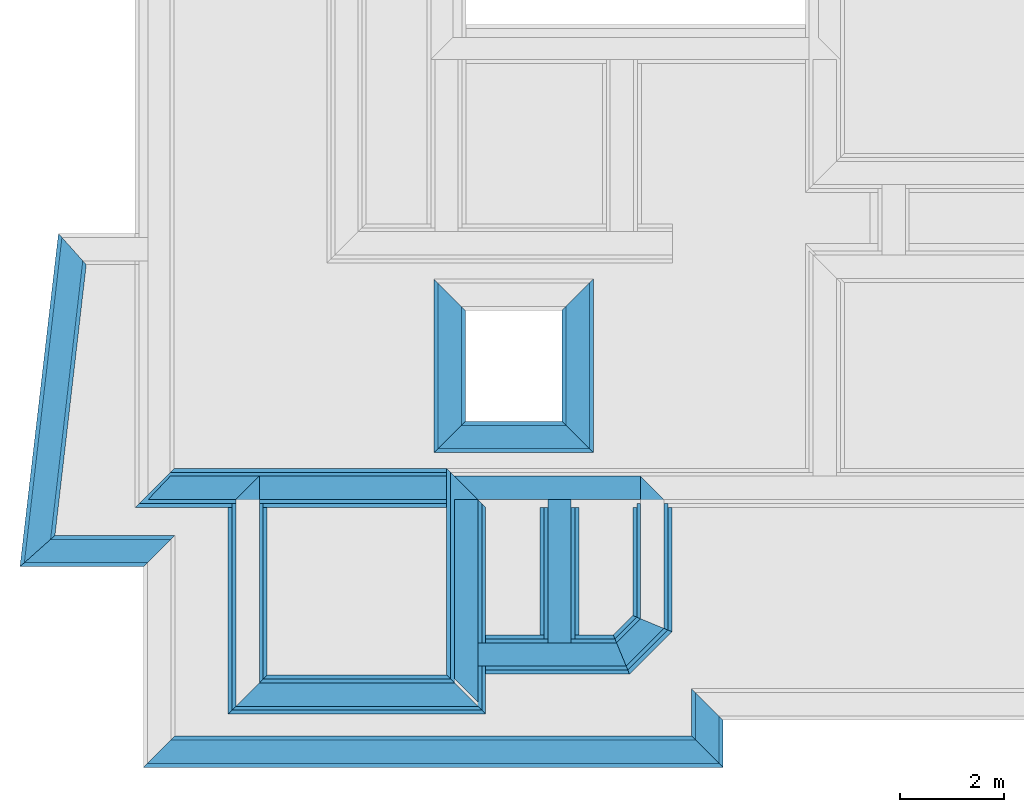
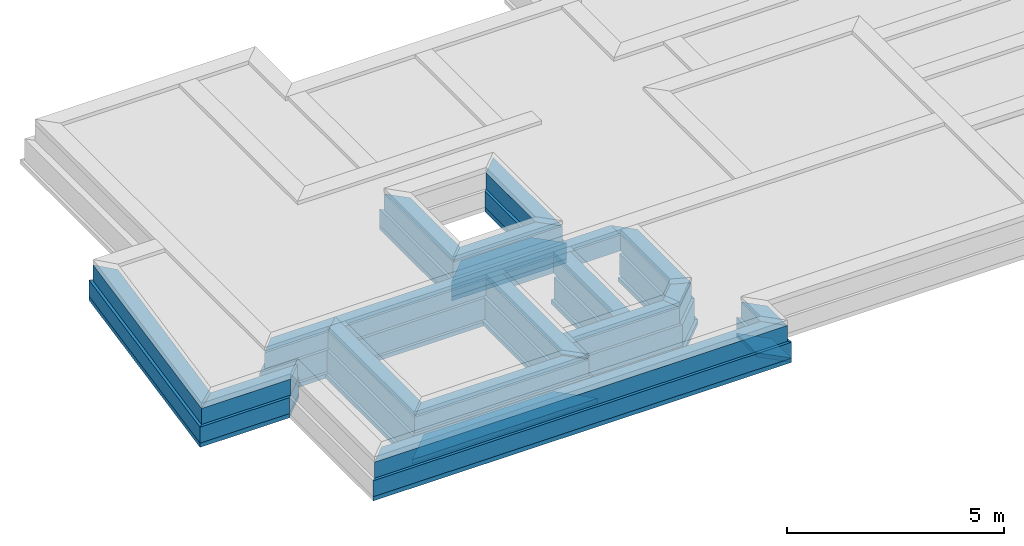
# One storey, part 2 of 6: 46 walls.
"""IFC4X3_ADD2 building model written with IfcOpenShell, lengths in metres."""

from ifc_helpers import new_model, entity, si_unit, converted_unit, frame, origin_with_axes, origin_2d_with_axis, place, context, subcontext, project, spatial, line, indexed_curve, outline, extrude, material, layer, layer_set, layer_usage, type_object, element, save


model = new_model("IFC4X3_ADD2")

# Units and contexts
model_context = context("Model", 3, precision=1e-05, world=origin_with_axes())
plan_context = context("Plan", 2, precision=1e-05, world=origin_2d_with_axis())
body_context = subcontext(model_context, "Body", "Model", "MODEL_VIEW")
ifc_project = project(units=[si_unit("VOLUMEUNIT", "CUBIC_METRE"), si_unit("LENGTHUNIT", "METRE"), converted_unit("PLANEANGLEUNIT", "degree", entity("IfcReal", 0.0174532925199433), si_unit("PLANEANGLEUNIT", "RADIAN"), dimensions=[0, 0, 0, 0, 0, 0, 0]), si_unit("AREAUNIT", "SQUARE_METRE")], contexts=[model_context, plan_context])

# Site, building, storey
site_placement = place(None, origin_with_axes())
site = spatial("IfcSite", under=ifc_project, at=site_placement)
building_placement = place(site_placement, origin_with_axes())
building = spatial("IfcBuilding", under=site, at=building_placement, Name="Building")
storey_placement = place(building_placement, frame((0.0, 0.0, -0.870000004768372), z_axis=(0.0, 0.0, 1.0), x_axis=(1.0, 0.0, 0.0)))
storey = spatial("IfcBuildingStorey", under=building, at=storey_placement, Name="Footing")

# Walls
ifc_material_1 = material(Name="Stone", Category="Structure")
ifc_layer_1 = layer(ifc_material_1, 0.449999988079071)
ifc_layer_set_1 = layer_set([ifc_layer_1])
ifc_layer_usage_1 = layer_usage(ifc_layer_set_1, "AXIS2", "POSITIVE", 0.0)
wall_type_1 = type_object("IfcWallType", Name="RRB Basement", PredefinedType="SHEAR", material=ifc_layer_set_1)
wall_1_placement = place(storey_placement, frame((15.1466770042094, 13.3349130268063, 0.719999998807908), z_axis=(0.0, 0.0, 1.0), x_axis=(3.13916473260163e-07, 0.999999999999951, 0.0)))
element("IfcWall", 1, at=wall_1_placement, inside=storey, type_object=wall_type_1, material=ifc_layer_usage_1, Name="Wall", context=body_context, shape_type="SweptSolid", body=[
    extrude(outline(indexed_curve([(0.0, 0.0), (0.186396055761703, 0.449999988079071), (2.93110990416569, 0.449999988079071), (2.48110978576698, 0.0)], segments=[line(1, 2, 3, 4, 1)])), origin_with_axes(), (0.0, 0.0, 1.0), 0.449999988079071),
])
ifc_layer_usage_2 = layer_usage(ifc_layer_set_1, "AXIS2", "POSITIVE", 0.0)
wall_2_placement = place(storey_placement, frame((7.35359666377311, 12.2860256676357, 0.719999998807908), z_axis=(0.0, 0.0, 1.0), x_axis=(3.13916473260163e-07, 0.999999999999951, 0.0)))
element("IfcWall", 2, at=wall_2_placement, inside=storey, type_object=wall_type_1, material=ifc_layer_usage_2, Name="Wall", context=body_context, shape_type="SweptSolid", body=[
    extrude(outline(indexed_curve([(0.0, 0.0), (-0.449999961074437, 0.449999988079071), (3.52999582324251, 0.449999988079071), (3.97999606087995, 0.0)], segments=[line(1, 2, 3, 4, 1)])), origin_with_axes(), (0.0, 0.0, 1.0), 0.449999988079071),
])
ifc_layer_usage_3 = layer_usage(ifc_layer_set_1, "AXIS2", "POSITIVE", 0.0)
wall_3_placement = place(storey_placement, frame((11.5629977944495, 12.3610239028931, 0.719999998807908), z_axis=(0.0, 0.0, 1.0), x_axis=(3.13916473260163e-07, 0.999999999999951, 0.0)))
element("IfcWall", 3, at=wall_3_placement, inside=storey, type_object=wall_type_1, material=ifc_layer_usage_3, Name="Wall", context=body_context, shape_type="SweptSolid", body=[
    extrude(outline(indexed_curve([(-0.449999988079072, 0.0), (2.68782058983727e-08, 0.449999988079071), (3.45499654674015, 0.449999988079071), (3.454996452804, 0.0)], segments=[line(1, 2, 3, 4, 1)])), origin_with_axes(), (0.0, 0.0, 1.0), 0.449999988079071),
])
ifc_layer_usage_4 = layer_usage(ifc_layer_set_1, "AXIS2", "POSITIVE", 0.0)
wall_4_placement = place(storey_placement, frame((14.4189835934303, 12.6072198349405, 0.719999998807908), z_axis=(0.0, 0.0, 1.0), x_axis=(0.707106840791191, 0.707106721581899, 0.0)))
element("IfcWall", 4, at=wall_4_placement, inside=storey, type_object=wall_type_1, material=ifc_layer_usage_4, Name="Wall", context=body_context, shape_type="SweptSolid", body=[
    extrude(outline(indexed_curve([(0.0, 0.0), (0.186396239135942, 0.449999988079071), (0.842717773351463, 0.449999988079071), (1.02911380402565, 0.0)], segments=[line(1, 2, 3, 4, 1)])), origin_with_axes(), (0.0, 0.0, 1.0), 0.449999988079071),
])
ifc_layer_usage_5 = layer_usage(ifc_layer_set_1, "AXIS2", "POSITIVE", 0.0)
wall_5_placement = place(storey_placement, frame((13.3589563840624, 12.6072204919225, 0.719999998807908), z_axis=(0.0, 0.0, 1.0), x_axis=(3.13916473260163e-07, 0.999999999999951, 0.0)))
element("IfcWall", 5, at=wall_5_placement, inside=storey, type_object=wall_type_1, material=ifc_layer_usage_5, Name="Wall", context=body_context, shape_type="SweptSolid", body=[
    extrude(outline(indexed_curve([(0.449999988079092, 0.0), (0.450000125309711, 0.449999988079071), (3.20880352988753, 0.449999988079071), (3.20880339956792, 0.0)], segments=[line(1, 2, 3, 4, 1)])), origin_with_axes(), (0.0, 0.0, 1.0), 0.449999988079071),
])
ifc_layer_usage_6 = layer_usage(ifc_layer_set_1, "AXIS2", "POSITIVE", 0.0)
wall_6_placement = place(storey_placement, frame((15.1466780013493, 16.2660184840428, 0.719999998807908), z_axis=(0.0, 0.0, 1.0), x_axis=(-0.999999999999924, 3.89414367418765e-07, 0.0)))
element("IfcWall", 6, at=wall_6_placement, inside=storey, type_object=wall_type_1, material=ifc_layer_usage_6, Name="Wall", context=body_context, shape_type="SweptSolid", body=[
    extrude(outline(indexed_curve([(0.449999988079071, 0.0), (0.449999965929192, 0.449999988079071), (7.79307999653564, 0.449999988079071), (7.79308002299699, 0.0)], segments=[line(1, 2, 3, 4, 1)])), origin_with_axes(), (0.0, 0.0, 1.0), 0.449999988079071),
])
ifc_layer_usage_7 = layer_usage(ifc_layer_set_1, "AXIS2", "POSITIVE", 0.0)
wall_7_placement = place(storey_placement, frame((11.5629977696537, 12.2860240936279, 0.719999998807908), z_axis=(0.0, 0.0, 1.0), x_axis=(-0.999999999999924, 3.89414367418765e-07, 0.0)))
element("IfcWall", 7, at=wall_7_placement, inside=storey, type_object=wall_type_1, material=ifc_layer_usage_7, Name="Wall", context=body_context, shape_type="SweptSolid", body=[
    extrude(outline(indexed_curve([(0.449999988079072, 0.0), (-2.6461350745525e-08, 0.449999988079071), (4.65940106875073, 0.449999988079071), (4.20940110713301, 0.0)], segments=[line(1, 2, 3, 4, 1)])), origin_with_axes(), (0.0, 0.0, 1.0), 0.449999988079071),
])
ifc_layer_usage_8 = layer_usage(ifc_layer_set_1, "AXIS2", "POSITIVE", 0.0)
wall_8_placement = place(storey_placement, frame((11.5629978758452, 12.6072216033935, 0.719999998807908), z_axis=(0.0, 0.0, 1.0), x_axis=(0.999999999999822, -5.960464477538e-07, 0.0)))
element("IfcWall", 8, at=wall_8_placement, inside=storey, type_object=wall_type_1, material=ifc_layer_usage_8, Name="Wall", context=body_context, shape_type="SweptSolid", body=[
    extrude(outline(indexed_curve([(0.0, 0.0), (-1.19445784433059e-07, 0.449999988079071), (2.66958956740739, 0.449999988079071), (2.85598578373842, 0.0)], segments=[line(1, 2, 3, 4, 1)])), origin_with_axes(), (0.0, 0.0, 1.0), 0.449999988079071),
])
ifc_layer_usage_9 = layer_usage(ifc_layer_set_1, "AXIS2", "POSITIVE", 0.0)
wall_9_placement = place(storey_placement, frame((7.35359797835293, 16.2660217285155, 0.719999998807908), z_axis=(0.0, 0.0, 1.0), x_axis=(-0.999999999999924, 3.89414367418765e-07, 0.0)))
element("IfcWall", 9, at=wall_9_placement, inside=storey, type_object=wall_type_1, material=ifc_layer_usage_9, Name="Wall", context=body_context, shape_type="SweptSolid", body=[
    extrude(outline(indexed_curve([(0.0, 0.0), (0.449999961617721, 0.449999988079071), (2.13955890890689, 0.449999988079071), (1.714558939226, 0.0)], segments=[line(1, 2, 3, 4, 1)])), origin_with_axes(), (0.0, 0.0, 1.0), 0.449999988079071),
])
ifc_layer_usage_10 = layer_usage(ifc_layer_set_1, "AXIS2", "POSITIVE", 0.0)
wall_10_placement = place(storey_placement, frame((5.65271663666227, 10.7361380519159, 0.719999998807908), z_axis=(0.0, 0.0, 1.0), x_axis=(0.999999999999822, -5.960464477538e-07, 0.0)))
element("IfcWall", 10, at=wall_10_placement, inside=storey, type_object=wall_type_1, material=ifc_layer_usage_10, Name="Wall", context=body_context, shape_type="SweptSolid", body=[
    extrude(outline(indexed_curve([(-0.449999988079075, 0.0), (5.25674046514268e-08, 0.449999988079071), (10.1013277162238, 0.449999988079071), (10.5513277053796, 0.0)], segments=[line(1, 2, 3, 4, 1)])), origin_with_axes(), (0.0, 0.0, 1.0), 0.449999988079071),
])
ifc_layer_usage_11 = layer_usage(ifc_layer_set_1, "AXIS2", "POSITIVE", 0.0)
wall_11_placement = place(storey_placement, frame((16.20404434204, 10.736131697641, 0.719999998807908), z_axis=(0.0, 0.0, 1.0), x_axis=(5.52335052361657e-07, 0.999999999999847, 0.0)))
element("IfcWall", 11, at=wall_11_placement, inside=storey, type_object=wall_type_1, material=ifc_layer_usage_11, Name="Wall", context=body_context, shape_type="SweptSolid", body=[
    extrude(outline(indexed_curve([(0.0, 0.0), (0.450000014070418, 0.449999988079071), (1.36321715701571, 0.449999988079071), (0.913217137078231, 0.0)], segments=[line(1, 2, 3, 4, 1)])), origin_with_axes(), (0.0, 0.0, 1.0), 0.449999988079071),
])
ifc_layer_usage_12 = layer_usage(ifc_layer_set_1, "AXIS2", "POSITIVE", 0.0)
wall_12_placement = place(storey_placement, frame((5.65271957159687, 15.0503759384137, 0.719999998807908), z_axis=(0.0, 0.0, 1.0), x_axis=(-0.999999999999803, 6.27832946520233e-07, 0.0)))
element("IfcWall", 12, at=wall_12_placement, inside=storey, type_object=wall_type_1, material=ifc_layer_usage_12, Name="Wall", context=body_context, shape_type="SweptSolid", body=[
    extrude(outline(indexed_curve([(0.0, 0.0), (0.450000011684951, 0.449999988079071), (2.82171083416142, 0.449999988079071), (2.31674855085093, 0.0)], segments=[line(1, 2, 3, 4, 1)])), origin_with_axes(), (0.0, 0.0, 1.0), 0.449999988079071),
])
ifc_layer_usage_13 = layer_usage(ifc_layer_set_1, "AXIS2", "POSITIVE", 0.0)
wall_13_placement = place(storey_placement, frame((11.2456821454564, 17.2460187833052, 0.719999998807908), z_axis=(0.0, 0.0, 1.0), x_axis=(6.71544341912371e-07, 0.999999999999775, 0.0)))
element("IfcWall", 13, at=wall_13_placement, inside=storey, type_object=wall_type_1, material=ifc_layer_usage_13, Name="Wall", context=body_context, shape_type="SweptSolid", body=[
    extrude(outline(indexed_curve([(0.0, 0.0), (-0.449999999482186, 0.449999988079071), (2.73836903409186, 0.449999988079071), (2.28836904708957, 0.0)], segments=[line(1, 2, 3, 4, 1)])), origin_with_axes(), (0.0, 0.0, 1.0), 0.449999988079071),
])
ifc_layer_usage_14 = layer_usage(ifc_layer_set_1, "AXIS2", "POSITIVE", 0.0)
wall_14_placement = place(storey_placement, frame((13.7089580548791, 17.2460171915262, 0.719999998807908), z_axis=(0.0, 0.0, 1.0), x_axis=(6.71544341912371e-07, 0.999999999999775, 0.0)))
element("IfcWall", 14, at=wall_14_placement, inside=storey, type_object=wall_type_1, material=ifc_layer_usage_14, Name="Wall", context=body_context, shape_type="SweptSolid", body=[
    extrude(outline(indexed_curve([(-0.449999988079071, 0.0), (-1.14031152298466e-08, 0.449999988079071), (2.2883689947009, 0.449999988079071), (2.73836899555693, 0.0)], segments=[line(1, 2, 3, 4, 1)])), origin_with_axes(), (0.0, 0.0, 1.0), 0.449999988079071),
])
ifc_layer_usage_15 = layer_usage(ifc_layer_set_1, "AXIS2", "POSITIVE", 0.0)
wall_15_placement = place(storey_placement, frame((13.7089580548791, 17.2460171990466, 0.719999983906746), z_axis=(0.0, 0.0, 1.0), x_axis=(-0.999999999999803, 6.27832946520233e-07, 0.0)))
element("IfcWall", 15, at=wall_15_placement, inside=storey, type_object=wall_type_1, material=ifc_layer_usage_15, Name="Wall", context=body_context, shape_type="SweptSolid", body=[
    extrude(outline(indexed_curve([(0.449999988079072, 0.0), (2.58708144351694e-08, 0.449999988079071), (2.91327592337316, 0.449999988079071), (2.46327590942327, 0.0)], segments=[line(1, 2, 3, 4, 1)])), origin_with_axes(), (0.0, 0.0, 1.0), 0.449999988079071),
])
ifc_layer_usage_16 = layer_usage(ifc_layer_set_1, "AXIS2", "POSITIVE", 0.0)
wall_16_placement = place(storey_placement, frame((3.55434743009632, 20.8634848330948, 0.719999998807908), z_axis=(0.0, 0.0, 1.0), x_axis=(-0.114729399557727, -0.99339678118923, 0.0)))
element("IfcWall", 16, at=wall_16_placement, inside=storey, type_object=wall_type_1, material=ifc_layer_usage_16, Name="Wall", context=body_context, shape_type="SweptSolid", body=[
    extrude(outline(indexed_curve([(0.0, 0.0), (0.401020051245883, 0.449999988079071), (5.79977630955525, 0.449999988079071), (6.30473856476878, 0.0)], segments=[line(1, 2, 3, 4, 1)])), origin_with_axes(), (0.0, 0.0, 1.0), 0.449999988079071),
])
ifc_material_2 = material(Name="Wall")
ifc_layer_2 = layer(ifc_material_2, 0.600000023841858, Name="concrete")
ifc_layer_set_2 = layer_set([ifc_layer_2], Name="concrete")
ifc_layer_usage_17 = layer_usage(ifc_layer_set_2, "AXIS2", "POSITIVE", 0.0)
wall_type_2 = type_object("IfcWallType", Name="RRB Foundation", PredefinedType="SHEAR", material=ifc_layer_set_2)
wall_17_placement = place(storey_placement, frame((14.4500515221254, 12.5322200975236, 0.120000004768372), z_axis=(0.0, 0.0, 1.0), x_axis=(0.707106840791191, 0.707106721581899, 0.0)))
element("IfcWall", 17, at=wall_17_placement, inside=storey, type_object=wall_type_2, material=ifc_layer_usage_17, Name="Wall", context=body_context, shape_type="SweptSolid", body=[
    extrude(outline(indexed_curve([(0.0, 0.0), (0.248528335537855, 0.600000023841858), (0.842714835397712, 0.600000023841858), (1.09124289229101, 0.0)], segments=[line(1, 2, 3, 4, 1)])), origin_with_axes(), (0.0, 0.0, 1.0), 0.600000023841858),
])
ifc_layer_usage_18 = layer_usage(ifc_layer_set_2, "AXIS2", "POSITIVE", 0.0)
wall_18_placement = place(storey_placement, frame((11.6379976037146, 12.3610239320991, 0.120000004768372), z_axis=(0.0, 0.0, 1.0), x_axis=(-0.999999999999924, 3.89414367418765e-07, 0.0)))
element("IfcWall", 18, at=wall_18_placement, inside=storey, type_object=wall_type_2, material=ifc_layer_usage_18, Name="Wall", context=body_context, shape_type="SweptSolid", body=[
    extrude(outline(indexed_curve([(0.600000023841859, 0.0), (-3.37259327238358e-08, 0.600000023841858), (4.80940064221081, 0.600000023841858), (4.20940065383951, 0.0)], segments=[line(1, 2, 3, 4, 1)])), origin_with_axes(), (0.0, 0.0, 1.0), 0.600000023841858),
])
ifc_layer_usage_19 = layer_usage(ifc_layer_set_2, "AXIS2", "POSITIVE", 0.0)
wall_19_placement = place(storey_placement, frame((13.4339570999146, 12.457221031189, 0.120000004768372), z_axis=(0.0, 0.0, 1.0), x_axis=(3.13916473260163e-07, 0.999999999999951, 0.0)))
element("IfcWall", 19, at=wall_19_placement, inside=storey, type_object=wall_type_2, material=ifc_layer_usage_19, Name="Wall", context=body_context, shape_type="SweptSolid", body=[
    extrude(outline(indexed_curve([(0.600000023841886, 0.0), (0.600000207250802, 0.600000023841858), (3.20880245678658, 0.600000023841858), (3.20880245678658, 0.0)], segments=[line(1, 2, 3, 4, 1)])), origin_with_axes(), (0.0, 0.0, 1.0), 0.600000023841858),
])
ifc_layer_usage_20 = layer_usage(ifc_layer_set_2, "AXIS2", "POSITIVE", 0.0)
wall_20_placement = place(storey_placement, frame((11.6379989301293, 16.3410187059637, 0.120000004768372), z_axis=(0.0, 0.0, 1.0), x_axis=(-0.999999999999924, 3.89414367418765e-07, 0.0)))
element("IfcWall", 20, at=wall_20_placement, inside=storey, type_object=wall_type_2, material=ifc_layer_usage_20, Name="Wall", context=body_context, shape_type="SweptSolid", body=[
    extrude(outline(indexed_curve([(0.600000023841859, 0.0), (0.599999990115926, 0.600000023841858), (6.59895989615596, 0.600000023841858), (5.9989599137992, 0.0)], segments=[line(1, 2, 3, 4, 1)])), origin_with_axes(), (0.0, 0.0, 1.0), 0.600000023841858),
])
ifc_layer_usage_21 = layer_usage(ifc_layer_set_2, "AXIS2", "POSITIVE", 0.0)
wall_21_placement = place(storey_placement, frame((7.42859694987542, 12.3610255061067, 0.120000004768372), z_axis=(0.0, 0.0, 1.0), x_axis=(3.13916473260163e-07, 0.999999999999951, 0.0)))
element("IfcWall", 21, at=wall_21_placement, inside=storey, type_object=wall_type_2, material=ifc_layer_usage_21, Name="Wall", context=body_context, shape_type="SweptSolid", body=[
    extrude(outline(indexed_curve([(0.0, 0.0), (-0.599999987835678, 0.600000023841858), (3.3799948082492, 0.600000023841858), (3.37999476947094, 0.0)], segments=[line(1, 2, 3, 4, 1)])), origin_with_axes(), (0.0, 0.0, 1.0), 0.600000023841858),
])
ifc_layer_usage_22 = layer_usage(ifc_layer_set_2, "AXIS2", "POSITIVE", 0.0)
wall_22_placement = place(storey_placement, frame((11.7129974686632, 12.5322217941284, 0.120000004768372), z_axis=(0.0, 0.0, 1.0), x_axis=(0.999999999999822, -5.960464477538e-07, 0.0)))
element("IfcWall", 22, at=wall_22_placement, inside=storey, type_object=wall_type_2, material=ifc_layer_usage_22, Name="Wall", context=body_context, shape_type="SweptSolid", body=[
    extrude(outline(indexed_curve([(0.0, 0.0), (-1.57167747032798e-07, 0.600000023841858), (2.48852581879504, 0.600000023841858), (2.73705412682357, 0.0)], segments=[line(1, 2, 3, 4, 1)])), origin_with_axes(), (0.0, 0.0, 1.0), 0.600000023841858),
])
ifc_layer_usage_23 = layer_usage(ifc_layer_set_2, "AXIS2", "POSITIVE", 0.0)
wall_23_placement = place(storey_placement, frame((15.2216768362291, 13.3038451893435, 0.120000004768372), z_axis=(0.0, 0.0, 1.0), x_axis=(3.13916473260163e-07, 0.999999999999951, 0.0)))
element("IfcWall", 23, at=wall_23_placement, inside=storey, type_object=wall_type_2, material=ifc_layer_usage_23, Name="Wall", context=body_context, shape_type="SweptSolid", body=[
    extrude(outline(indexed_curve([(0.0, 0.0), (0.248528087591311, 0.600000023841858), (2.43717784407926, 0.600000023841858), (2.43717767159818, 0.0)], segments=[line(1, 2, 3, 4, 1)])), origin_with_axes(), (0.0, 0.0, 1.0), 0.600000023841858),
])
ifc_layer_usage_24 = layer_usage(ifc_layer_set_2, "AXIS2", "POSITIVE", 0.0)
wall_24_placement = place(storey_placement, frame((11.6379976037146, 12.3610239309375, 0.120000004768372), z_axis=(0.0, 0.0, 1.0), x_axis=(3.13916473260163e-07, 0.999999999999951, 0.0)))
element("IfcWall", 24, at=wall_24_placement, inside=storey, type_object=wall_type_2, material=ifc_layer_usage_24, Name="Wall", context=body_context, shape_type="SweptSolid", body=[
    extrude(outline(indexed_curve([(-0.600000023841859, 0.0), (3.60061807869183e-08, 0.600000023841858), (3.98000128109723, 0.600000023841858), (3.38000108477427, 0.0)], segments=[line(1, 2, 3, 4, 1)])), origin_with_axes(), (0.0, 0.0, 1.0), 0.600000023841858),
])
ifc_layer_usage_25 = layer_usage(ifc_layer_set_2, "AXIS2", "POSITIVE", 0.0)
wall_25_placement = place(storey_placement, frame((15.6790454136462, 11.2611335276763, 0.269999980926514), z_axis=(0.0, 0.0, 1.0), x_axis=(-0.999999999999924, 3.89414367418765e-07, 0.0)))
element("IfcWall", 25, at=wall_25_placement, inside=storey, type_object=wall_type_2, material=ifc_layer_usage_25, Name="Wall", context=body_context, shape_type="SweptSolid", body=[
    extrude(outline(indexed_curve([(0.0, 0.0), (-0.599998054716328, 0.600000023841858), (10.5513305503478, 0.600000023841858), (9.95133056357225, 0.0)], segments=[line(1, 2, 3, 4, 1)])), origin_with_axes(), (0.0, 0.0, 1.0), 0.449999988079071),
])
ifc_layer_usage_26 = layer_usage(ifc_layer_set_2, "AXIS2", "POSITIVE", 0.0)
wall_26_placement = place(storey_placement, frame((15.6790487663207, 12.174347695086, 0.269999980926514), z_axis=(0.0, 0.0, 1.0), x_axis=(-5.2054855359522e-07, -0.999999999999865, 0.0)))
element("IfcWall", 26, at=wall_26_placement, inside=storey, type_object=wall_type_2, material=ifc_layer_usage_26, Name="Wall", context=body_context, shape_type="SweptSolid", body=[
    extrude(outline(indexed_curve([(0.0, 0.0), (0.599999939609788, 0.600000023841858), (1.51321410886504, 0.600000023841858), (0.913214167410906, 0.0)], segments=[line(1, 2, 3, 4, 1)])), origin_with_axes(), (0.0, 0.0, 1.0), 0.449999988079071),
])
ifc_layer_usage_27 = layer_usage(ifc_layer_set_2, "AXIS2", "POSITIVE", 0.0)
wall_27_placement = place(storey_placement, frame((5.1277161086956, 15.1253715470741, 0.269999980926514), z_axis=(0.0, 0.0, 1.0), x_axis=(-0.999999999999803, 6.27832946520233e-07, 0.0)))
element("IfcWall", 27, at=wall_27_placement, inside=storey, type_object=wall_type_2, material=ifc_layer_usage_27, Name="Wall", context=body_context, shape_type="SweptSolid", body=[
    extrude(outline(indexed_curve([(-0.600000023841874, 0.0), (-1.77571658523227e-07, 0.600000023841858), (2.38086932746782, 0.600000023841858), (1.7075862513005, 0.0)], segments=[line(1, 2, 3, 4, 1)])), origin_with_axes(), (0.0, 0.0, 1.0), 0.449999988079071),
])
ifc_layer_usage_28 = layer_usage(ifc_layer_set_2, "AXIS2", "POSITIVE", 0.0)
wall_28_placement = place(storey_placement, frame((10.7206868734992, 19.4593928708772, 0.269999980926514), z_axis=(0.0, 0.0, 1.0), x_axis=(-5.2054855359522e-07, -0.999999999999865, 0.0)))
element("IfcWall", 28, at=wall_28_placement, inside=storey, type_object=wall_type_2, material=ifc_layer_usage_28, Name="Wall", context=body_context, shape_type="SweptSolid", body=[
    extrude(outline(indexed_curve([(-0.600000023841776, 0.0), (1.86421843027806e-06, 0.600000023841858), (2.13837337255072, 0.600000023841858), (2.73837258208978, 0.0)], segments=[line(1, 2, 3, 4, 1)])), origin_with_axes(), (0.0, 0.0, 1.0), 0.449999988079071),
])
ifc_layer_usage_29 = layer_usage(ifc_layer_set_2, "AXIS2", "POSITIVE", 0.0)
wall_29_placement = place(storey_placement, frame((13.1839627829191, 19.459385224953, 0.269999980926514), z_axis=(0.0, 0.0, 1.0), x_axis=(-5.2054855359522e-07, -0.999999999999865, 0.0)))
element("IfcWall", 29, at=wall_29_placement, inside=storey, type_object=wall_type_2, material=ifc_layer_usage_29, Name="Wall", context=body_context, shape_type="SweptSolid", body=[
    extrude(outline(indexed_curve([(0.0, 0.0), (-0.599999349220907, 0.600000023841858), (2.73837037581012, 0.600000023841858), (2.13836953766554, 0.0)], segments=[line(1, 2, 3, 4, 1)])), origin_with_axes(), (0.0, 0.0, 1.0), 0.449999988079071),
])
ifc_layer_usage_30 = layer_usage(ifc_layer_set_2, "AXIS2", "POSITIVE", 0.0)
wall_30_placement = place(storey_placement, frame((10.7206825707411, 16.7210202888016, 0.269999980926514), z_axis=(0.0, 0.0, 1.0), x_axis=(0.999999999999886, -4.76837158203071e-07, 0.0)))
element("IfcWall", 30, at=wall_30_placement, inside=storey, type_object=wall_type_2, material=ifc_layer_usage_30, Name="Wall", context=body_context, shape_type="SweptSolid", body=[
    extrude(outline(indexed_curve([(0.0, 0.0), (0.600000680509379, 0.600000023841858), (2.46327656609531, 0.600000023841858), (3.06327593326901, 0.0)], segments=[line(1, 2, 3, 4, 1)])), origin_with_axes(), (0.0, 0.0, 1.0), 0.449999988079071),
])
ifc_layer_usage_31 = layer_usage(ifc_layer_set_2, "AXIS2", "POSITIVE", 0.0)
wall_31_placement = place(storey_placement, frame((3.48750964878186, 20.9384852020161, 0.269999980926514), z_axis=(0.0, 0.0, 1.0), x_axis=(-0.114729399557727, -0.99339678118923, 0.0)))
element("IfcWall", 31, at=wall_31_placement, inside=storey, type_object=wall_type_2, material=ifc_layer_usage_31, Name="Wall", context=body_context, shape_type="SweptSolid", body=[
    extrude(outline(indexed_curve([(0.0, 0.0), (0.534693409766792, 0.600000023841858), (5.78245779276086, 0.600000023841858), (6.45574087911888, 0.0)], segments=[line(1, 2, 3, 4, 1)])), origin_with_axes(), (0.0, 0.0, 1.0), 0.449999988079071),
])
ifc_layer_3 = layer(ifc_material_2, 0.75)
ifc_layer_set_3 = layer_set([ifc_layer_3])
ifc_layer_usage_32 = layer_usage(ifc_layer_set_3, "AXIS2", "POSITIVE", 0.0)
wall_type_3 = type_object("IfcWallType", Name="PCC 120mm", PredefinedType="SHEAR", material=ifc_layer_set_3)
wall_32_placement = place(storey_placement, frame((11.712997086914, 12.4360237607739, 0.0), z_axis=(0.0, 0.0, 1.0), x_axis=(-0.999999999999924, 3.89414367418765e-07, 0.0)))
element("IfcWall", 32, at=wall_32_placement, inside=storey, type_object=wall_type_3, material=ifc_layer_usage_32, Name="Wall", context=body_context, shape_type="SweptSolid", body=[
    extrude(outline(indexed_curve([(0.75, 0.0), (-3.451784469366e-08, 0.75), (4.95940036665373, 0.75), (4.20940041099193, 0.0)], segments=[line(1, 2, 3, 4, 1)])), origin_with_axes(), (0.0, 0.0, 1.0), 0.119999997317791),
])
ifc_layer_usage_33 = layer_usage(ifc_layer_set_3, "AXIS2", "POSITIVE", 0.0)
wall_33_placement = place(storey_placement, frame((7.50359667592235, 12.4360253347814, 0.0), z_axis=(0.0, 0.0, 1.0), x_axis=(3.13916473260163e-07, 0.999999999999951, 0.0)))
element("IfcWall", 33, at=wall_33_placement, inside=storey, type_object=wall_type_3, material=ifc_layer_usage_33, Name="Wall", context=body_context, shape_type="SweptSolid", body=[
    extrude(outline(indexed_curve([(0.0, 0.0), (-0.7499999546577, 0.75), (3.22999572040198, 0.75), (3.22999567211225, 0.0)], segments=[line(1, 2, 3, 4, 1)])), origin_with_axes(), (0.0, 0.0, 1.0), 0.119999997317791),
])
ifc_layer_usage_34 = layer_usage(ifc_layer_set_3, "AXIS2", "POSITIVE", 0.0)
wall_34_placement = place(storey_placement, frame((11.712998453607, 16.4160194137244, 0.0), z_axis=(0.0, 0.0, 1.0), x_axis=(-0.999999999999924, 3.89414367418765e-07, 0.0)))
element("IfcWall", 34, at=wall_34_placement, inside=storey, type_object=wall_type_3, material=ifc_layer_usage_34, Name="Wall", context=body_context, shape_type="SweptSolid", body=[
    extrude(outline(indexed_curve([(0.750000000000001, 0.0), (0.749999958514383, 0.75), (6.74895961318927, 0.75), (5.99895966504564, 0.0)], segments=[line(1, 2, 3, 4, 1)])), origin_with_axes(), (0.0, 0.0, 1.0), 0.119999997317791),
])
ifc_layer_usage_35 = layer_usage(ifc_layer_set_3, "AXIS2", "POSITIVE", 0.0)
wall_35_placement = place(storey_placement, frame((11.7129971169219, 12.4360237607738, 0.0), z_axis=(0.0, 0.0, 1.0), x_axis=(3.13916473260163e-07, 0.999999999999951, 0.0)))
element("IfcWall", 35, at=wall_35_placement, inside=storey, type_object=wall_type_3, material=ifc_layer_usage_35, Name="Wall", context=body_context, shape_type="SweptSolid", body=[
    extrude(outline(indexed_curve([(-0.750000000000001, 0.0), (4.50077241979968e-08, 0.75), (3.98000111844521, 0.75), (3.23000090214441, 0.0)], segments=[line(1, 2, 3, 4, 1)])), origin_with_axes(), (0.0, 0.0, 1.0), 0.119999997317791),
])
ifc_layer_usage_36 = layer_usage(ifc_layer_set_3, "AXIS2", "POSITIVE", 0.0)
wall_36_placement = place(storey_placement, frame((13.5089565232207, 12.4572212834925, 0.0), z_axis=(0.0, 0.0, 1.0), x_axis=(3.13916473260163e-07, 0.999999999999951, 0.0)))
element("IfcWall", 36, at=wall_36_placement, inside=storey, type_object=wall_type_3, material=ifc_layer_usage_36, Name="Wall", context=body_context, shape_type="SweptSolid", body=[
    extrude(outline(indexed_curve([(0.750000000000037, 0.0), (0.75000023498831, 0.75), (3.20880251398879, 0.75), (3.20880229768802, 0.0)], segments=[line(1, 2, 3, 4, 1)])), origin_with_axes(), (0.0, 0.0, 1.0), 0.119999997317791),
])
ifc_layer_usage_37 = layer_usage(ifc_layer_set_3, "AXIS2", "POSITIVE", 0.0)
wall_37_placement = place(storey_placement, frame((15.2966765831064, 13.2727789912786, 0.0), z_axis=(0.0, 0.0, 1.0), x_axis=(3.13916473260163e-07, 0.999999999999951, 0.0)))
element("IfcWall", 37, at=wall_37_placement, inside=storey, type_object=wall_type_3, material=ifc_layer_usage_37, Name="Wall", context=body_context, shape_type="SweptSolid", body=[
    extrude(outline(indexed_curve([(0.0, 0.0), (0.310660159435322, 0.75), (2.39324353560032, 0.75), (2.39324353560032, 0.0)], segments=[line(1, 2, 3, 4, 1)])), origin_with_axes(), (0.0, 0.0, 1.0), 0.119999997317791),
])
ifc_layer_usage_38 = layer_usage(ifc_layer_set_3, "AXIS2", "POSITIVE", 0.0)
wall_38_placement = place(storey_placement, frame((11.7129971240043, 12.4572223888417, 0.0), z_axis=(0.0, 0.0, 1.0), x_axis=(0.999999999999822, -5.960464477538e-07, 0.0)))
element("IfcWall", 38, at=wall_38_placement, inside=storey, type_object=wall_type_3, material=ifc_layer_usage_38, Name="Wall", context=body_context, shape_type="SweptSolid", body=[
    extrude(outline(indexed_curve([(0.0, 0.0), (-1.96459677970218e-07, 0.75), (2.45746044805216, 0.75), (2.76812074576488, 0.0)], segments=[line(1, 2, 3, 4, 1)])), origin_with_axes(), (0.0, 0.0, 1.0), 0.119999997317791),
])
ifc_layer_usage_39 = layer_usage(ifc_layer_set_3, "AXIS2", "POSITIVE", 0.0)
wall_39_placement = place(storey_placement, frame((14.4811177863082, 12.4572206554527, 0.0), z_axis=(0.0, 0.0, 1.0), x_axis=(0.707106960000462, 0.707106602372588, 0.0)))
element("IfcWall", 39, at=wall_39_placement, inside=storey, type_object=wall_type_3, material=ifc_layer_usage_39, Name="Wall", context=body_context, shape_type="SweptSolid", body=[
    extrude(outline(indexed_curve([(0.0, 0.0), (0.310660340087305, 0.75), (0.842713886681536, 0.75), (1.15337401967819, 0.0)], segments=[line(1, 2, 3, 4, 1)])), origin_with_axes(), (0.0, 0.0, 1.0), 0.119999997317791),
])
ifc_layer_4 = layer(ifc_material_2, 0.600000023841858, Name="concrete")
ifc_layer_set_4 = layer_set([ifc_layer_4], Name="concrete")
ifc_layer_usage_40 = layer_usage(ifc_layer_set_4, "AXIS2", "POSITIVE", 0.0)
wall_type_4 = type_object("IfcWallType", Name="60CM PCC", PredefinedType="SHEAR", material=ifc_layer_set_4)
wall_40_placement = place(storey_placement, frame((15.6790446116332, 11.2611338197374, 0.149999976158143), z_axis=(0.0, 0.0, 1.0), x_axis=(-0.999999999999924, 3.89414367418765e-07, 0.0)))
element("IfcWall", 40, at=wall_40_placement, inside=storey, type_object=wall_type_4, material=ifc_layer_usage_40, Name="Wall", context=body_context, shape_type="SweptSolid", body=[
    extrude(outline(indexed_curve([(0.0, 0.0), (-0.599999967920739, 0.600000023841858), (10.5513305175964, 0.600000023841858), (9.95133042542427, 0.0)], segments=[line(1, 2, 3, 4, 1)])), origin_with_axes(), (0.0, 0.0, 1.0), 0.119999997317791),
])
ifc_layer_usage_41 = layer_usage(ifc_layer_set_4, "AXIS2", "POSITIVE", 0.0)
wall_41_placement = place(storey_placement, frame((15.6790451172703, 12.1743476366754, 0.149999976158143), z_axis=(0.0, 0.0, 1.0), x_axis=(-6.39757843145941e-07, -0.999999999999795, 0.0)))
element("IfcWall", 41, at=wall_41_placement, inside=storey, type_object=wall_type_4, material=ifc_layer_usage_41, Name="Wall", context=body_context, shape_type="SweptSolid", body=[
    extrude(outline(indexed_curve([(0.0, 0.0), (0.599999868892124, 0.600000023841858), (1.51321368686675, 0.600000023841858), (0.913213816938183, 0.0)], segments=[line(1, 2, 3, 4, 1)])), origin_with_axes(), (0.0, 0.0, 1.0), 0.119999997317791),
])
ifc_layer_usage_42 = layer_usage(ifc_layer_set_4, "AXIS2", "POSITIVE", 0.0)
wall_42_placement = place(storey_placement, frame((5.12771610869562, 15.125371594162, 0.149999976158143), z_axis=(0.0, 0.0, 1.0), x_axis=(-0.999999999999803, 6.27832946520233e-07, 0.0)))
element("IfcWall", 42, at=wall_42_placement, inside=storey, type_object=wall_type_4, material=ifc_layer_usage_42, Name="Wall", context=body_context, shape_type="SweptSolid", body=[
    extrude(outline(indexed_curve([(-0.600000023841863, 0.0), (-7.44932391151584e-08, 0.600000023841858), (2.38086927250564, 0.600000023841858), (1.70758619634341, 0.0)], segments=[line(1, 2, 3, 4, 1)])), origin_with_axes(), (0.0, 0.0, 1.0), 0.119999997317791),
])
ifc_layer_usage_43 = layer_usage(ifc_layer_set_4, "AXIS2", "POSITIVE", 0.0)
wall_43_placement = place(storey_placement, frame((10.7206830498573, 19.4593854078441, 0.149999976158143), z_axis=(0.0, 0.0, 1.0), x_axis=(-6.39757843145941e-07, -0.999999999999795, 0.0)))
element("IfcWall", 43, at=wall_43_placement, inside=storey, type_object=wall_type_4, material=ifc_layer_usage_43, Name="Wall", context=body_context, shape_type="SweptSolid", body=[
    extrude(outline(indexed_curve([(-0.600000023841863, 0.0), (-1.26312289003283e-07, 0.600000023841858), (2.13836870318869, 0.600000023841858), (2.73836879775748, 0.0)], segments=[line(1, 2, 3, 4, 1)])), origin_with_axes(), (0.0, 0.0, 1.0), 0.119999997317791),
])
ifc_layer_usage_44 = layer_usage(ifc_layer_set_4, "AXIS2", "POSITIVE", 0.0)
wall_44_placement = place(storey_placement, frame((13.1839589592805, 19.4593842822288, 0.149999976158143), z_axis=(0.0, 0.0, 1.0), x_axis=(-6.39757843145941e-07, -0.999999999999795, 0.0)))
element("IfcWall", 44, at=wall_44_placement, inside=storey, type_object=wall_type_4, material=ifc_layer_usage_44, Name="Wall", context=body_context, shape_type="SweptSolid", body=[
    extrude(outline(indexed_curve([(0.0, 0.0), (-0.600000087173521, 0.600000023841858), (2.738368924705, 0.600000023841858), (2.1383689641948, 0.0)], segments=[line(1, 2, 3, 4, 1)])), origin_with_axes(), (0.0, 0.0, 1.0), 0.119999997317791),
])
ifc_layer_usage_45 = layer_usage(ifc_layer_set_4, "AXIS2", "POSITIVE", 0.0)
wall_45_placement = place(storey_placement, frame((10.7206814502968, 16.7210166100871, 0.149999976158143), z_axis=(0.0, 0.0, 1.0), x_axis=(0.999999999999822, -5.960464477538e-07, 0.0)))
element("IfcWall", 45, at=wall_45_placement, inside=storey, type_object=wall_type_4, material=ifc_layer_usage_45, Name="Wall", context=body_context, shape_type="SweptSolid", body=[
    extrude(outline(indexed_curve([(0.0, 0.0), (0.600000016691374, 0.600000023841858), (2.46327617193386, 0.600000023841858), (3.06327627858975, 0.0)], segments=[line(1, 2, 3, 4, 1)])), origin_with_axes(), (0.0, 0.0, 1.0), 0.119999997317791),
])
ifc_layer_usage_46 = layer_usage(ifc_layer_set_4, "AXIS2", "POSITIVE", 0.0)
wall_46_placement = place(storey_placement, frame((3.48750969788129, 20.9384852015846, 0.149999976158143), z_axis=(0.0, 0.0, 1.0), x_axis=(-0.114729399557727, -0.99339678118923, 0.0)))
element("IfcWall", 46, at=wall_46_placement, inside=storey, type_object=wall_type_4, material=ifc_layer_usage_46, Name="Wall", context=body_context, shape_type="SweptSolid", body=[
    extrude(outline(indexed_curve([(0.0, 0.0), (0.534693409828114, 0.600000023841858), (5.78245774519899, 0.600000023841858), (6.4557408316648, 0.0)], segments=[line(1, 2, 3, 4, 1)])), origin_with_axes(), (0.0, 0.0, 1.0), 0.119999997317791),
])

save(model, "model.ifc")
